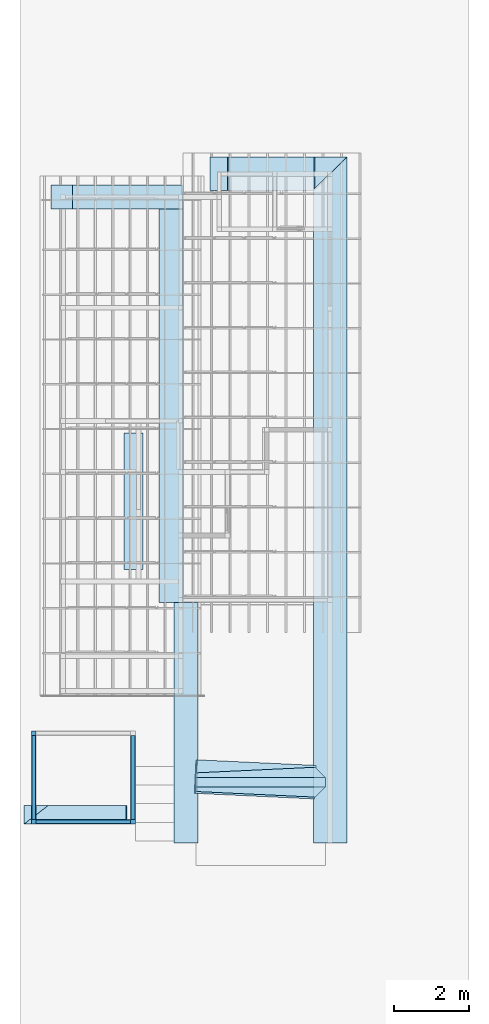
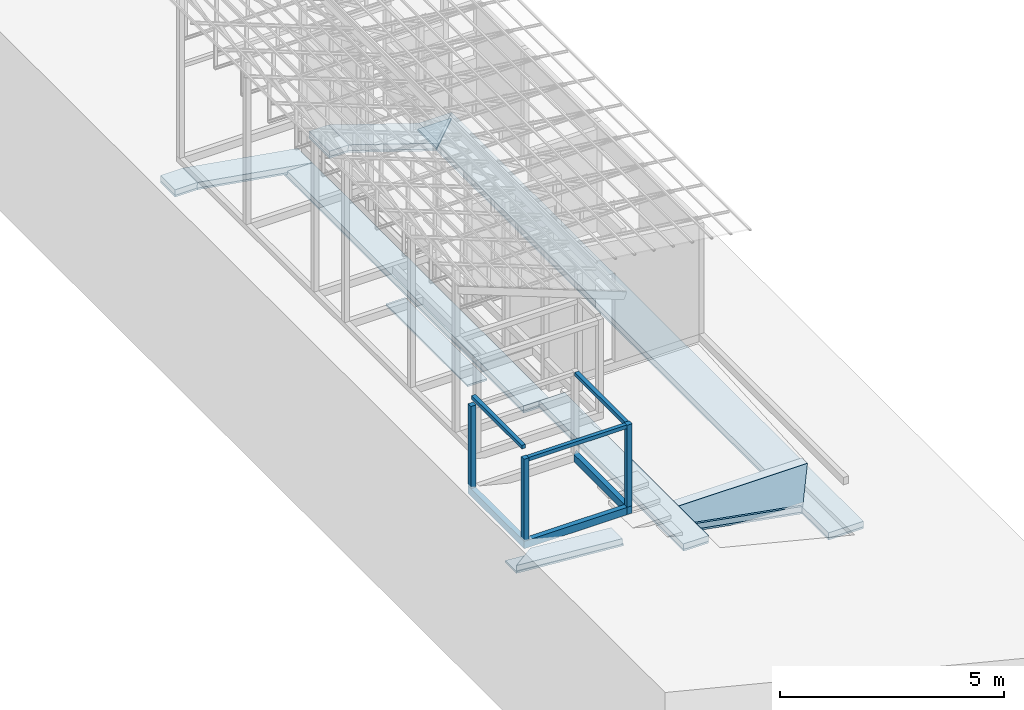
# One storey, part 1 of 22: 22 footings, 9 beams.
"""IFC4 building model written with IfcOpenShell, lengths in millimetres."""

import ifcopenshell
import ifcopenshell.guid

model = None  # the IFC model being written
_history = None  # IfcOwnerHistory: only IFC2X3 demands one
_inside = {}  # id of a spatial element -> (the spatial element, [elements in it])
_under = {}  # id of a project, library or spatial element -> (it, [spatial elements below it])
_declared = {}  # id of a project -> (the project, [libraries it declares])
_typed = {}  # id of a type object -> (the type object, [elements of that type])
_made_of = {}  # id of a material, layer set ... -> (it, [elements and type objects made of it])


def new_model(schema):
    """Start an empty IFC model of exactly this schema.

    Asked for "IFC4X3", IfcOpenShell would pick the latest addendum, in which some entities
    have other attributes; the version numbers below select the first issue.
    IFC2X3 requires an IfcOwnerHistory on every rooted entity: one is made here for all.
    """
    global model, _history
    if schema == "IFC4X3":
        model = ifcopenshell.file(schema_version=(4, 3, 0, 0))
    else:
        model = ifcopenshell.file(schema=schema)
    _inside.clear()
    _under.clear()
    _declared.clear()
    _typed.clear()
    _made_of.clear()
    _history = None
    if model.schema == "IFC2X3":
        org = make("IfcOrganization", Name="unknown")
        user = make(
            "IfcPersonAndOrganization",
            ThePerson=make("IfcPerson", FamilyName="unknown"),
            TheOrganization=org,
        )
        app = make(
            "IfcApplication",
            ApplicationDeveloper=org,
            Version="unknown",
            ApplicationFullName="unknown",
            ApplicationIdentifier="unknown",
        )
        _history = make(
            "IfcOwnerHistory",
            OwningUser=user,
            OwningApplication=app,
            ChangeAction="ADDED",
            CreationDate=0,
        )
    return model


def make(cls, **values):
    """One entity of the class cls with the attributes given. An attribute that is None is left unset."""
    return model.create_entity(
        cls, **{name: value for name, value in values.items() if value is not None}
    )


def entity(cls, *values):
    """Any entity or typed value of the class cls, its attributes in the order of the schema. None: left unset."""
    e = model.create_entity(cls)
    for i, value in enumerate(values):
        if value is not None:
            e[i] = value
    return e


def rooted(cls, **values):
    """An entity with a GlobalId (a new one), such as an element, a storey or a relation."""
    return make(cls, GlobalId=ifcopenshell.guid.new(), OwnerHistory=_history, **values)


def si_unit(unit_type, name, prefix=None):
    """IfcSIUnit, for example si_unit("LENGTHUNIT", "METRE", prefix="MILLI")."""
    return make("IfcSIUnit", UnitType=unit_type, Prefix=prefix, Name=name)


def converted_unit(unit_type, name, factor, base, dimensions=None, offset=None):
    """IfcConversionBasedUnit, such as the inch: factor (a typed value) times the base unit."""
    return make(
        "IfcConversionBasedUnit"
        if offset is None
        else "IfcConversionBasedUnitWithOffset",
        ConversionOffset=offset,
        Dimensions=None
        if dimensions is None
        else entity("IfcDimensionalExponents", *dimensions),
        UnitType=unit_type,
        Name=name,
        ConversionFactor=make(
            "IfcMeasureWithUnit", ValueComponent=factor, UnitComponent=base
        ),
    )


def assignment(units):
    """IfcUnitAssignment: the units of a project."""
    return None if units is None else make("IfcUnitAssignment", Units=units)


def point(xyz):
    """IfcCartesianPoint."""
    return None if xyz is None else make("IfcCartesianPoint", Coordinates=xyz)


def direction(xyz):
    """IfcDirection."""
    return None if xyz is None else make("IfcDirection", DirectionRatios=xyz)


def frame(location, z_axis=None, x_axis=None):
    """IfcAxis2Placement3D, a coordinate frame: its origin and axes. An axis left out is left unset."""
    return make(
        "IfcAxis2Placement3D",
        Location=point(location),
        Axis=direction(z_axis),
        RefDirection=direction(x_axis),
    )


def frame_2d(location, x_axis=None):
    """IfcAxis2Placement2D, a coordinate frame in the plane: its origin and x axis."""
    return make(
        "IfcAxis2Placement2D", Location=point(location), RefDirection=direction(x_axis)
    )


def origin_with_axes():
    """The frame at (0, 0, 0) with the z axis (0, 0, 1) and the x axis (1, 0, 0) written out."""
    return frame((0.0, 0.0, 0.0), z_axis=(0.0, 0.0, 1.0), x_axis=(1.0, 0.0, 0.0))


def origin_2d_with_axis():
    """The frame at (0, 0) in the plane with the x axis (1, 0) written out."""
    return frame_2d((0.0, 0.0), x_axis=(1.0, 0.0))


def place(relative_to, where):
    """IfcLocalPlacement: puts the frame where relative to a parent placement (None: the world)."""
    return make(
        "IfcLocalPlacement", PlacementRelTo=relative_to, RelativePlacement=where
    )


def context(
    kind, dimensions, precision=None, world=None, true_north=None, identifier=None
):
    """IfcGeometricRepresentationContext, for example the 3D "Model" context."""
    return make(
        "IfcGeometricRepresentationContext",
        ContextIdentifier=identifier,
        ContextType=kind,
        CoordinateSpaceDimension=dimensions,
        Precision=precision,
        WorldCoordinateSystem=world,
        TrueNorth=true_north,
    )


def subcontext(parent, identifier, kind, view, scale=None):
    """IfcGeometricRepresentationSubContext, for example "Body" below "Model"."""
    return make(
        "IfcGeometricRepresentationSubContext",
        ContextIdentifier=identifier,
        ContextType=kind,
        ParentContext=parent,
        TargetScale=scale,
        TargetView=view,
    )


def project(units=None, contexts=None):
    """IfcProject with its units and contexts."""
    return rooted(
        "IfcProject",
        Name="project",
        RepresentationContexts=contexts,
        UnitsInContext=assignment(units),
    )


def spatial(cls, under=None, at=None, **own):
    """A site, building, storey or space (cls), placed at a placement, below another one or the project."""
    s = rooted(cls, ObjectPlacement=at, **own)
    if under is not None:
        _under.setdefault(under.id(), (under, []))[1].append(s)
    return s


def point_list(points):
    """IfcCartesianPointList2D or 3D."""
    cls = (
        "IfcCartesianPointList2D" if len(points[0]) == 2 else "IfcCartesianPointList3D"
    )
    return make(cls, CoordList=points)


def indexed_curve(points, segments=None, self_intersect=None):
    """IfcIndexedPolyCurve: lines and arcs through numbered points (the first is 1)."""
    return make(
        "IfcIndexedPolyCurve",
        Points=point_list(points),
        Segments=segments,
        SelfIntersect=self_intersect,
    )


def profile(cls, at=None, kind="AREA", **sizes):
    """A parametric profile (cls). Its sizes go by their IFC names, for example OverallWidth=200.0."""
    return make(cls, ProfileType=kind, Position=at, **sizes)


def rectangle(**sizes):
    """IfcRectangleProfileDef."""
    return profile("IfcRectangleProfileDef", **sizes)


def outline(outer, holes=None, kind="AREA"):
    """IfcArbitraryClosedProfileDef: a profile drawn as a closed curve; with holes, ...WithVoids."""
    if holes is None:
        return make("IfcArbitraryClosedProfileDef", ProfileType=kind, OuterCurve=outer)
    return make(
        "IfcArbitraryProfileDefWithVoids",
        ProfileType=kind,
        OuterCurve=outer,
        InnerCurves=holes,
    )


def extrude(swept, where, along, depth):
    """IfcExtrudedAreaSolid: the profile swept, set in the frame where, extruded along a direction by depth."""
    return make(
        "IfcExtrudedAreaSolid",
        SweptArea=swept,
        Position=where,
        ExtrudedDirection=direction(along),
        Depth=depth,
    )


def clip(a, b, op="DIFFERENCE"):
    """IfcBooleanClippingResult: the solid a cut by the half space b."""
    return make(
        "IfcBooleanClippingResult", Operator=op, FirstOperand=a, SecondOperand=b
    )


def halfspace(plane, agree):
    """IfcHalfSpaceSolid: all space on one side of the plane z = 0 of the frame plane."""
    return make(
        "IfcHalfSpaceSolid",
        BaseSurface=make("IfcPlane", Position=plane),
        AgreementFlag=agree,
    )


def polygons(points, faces, closed=None, point_numbers=None):
    """IfcPolygonalFaceSet: a face is its outer loop, then its inner loops; points numbered from 1."""
    made = []
    for loops in faces:
        if len(loops) == 1:
            made.append(make("IfcIndexedPolygonalFace", CoordIndex=loops[0]))
        else:
            made.append(
                make(
                    "IfcIndexedPolygonalFaceWithVoids",
                    CoordIndex=loops[0],
                    InnerCoordIndices=loops[1:],
                )
            )
    return make(
        "IfcPolygonalFaceSet",
        Coordinates=point_list(points),
        Closed=closed,
        Faces=made,
        PnIndex=point_numbers,
    )


def shape(context_of_items, identifier, shape_type, items):
    """IfcShapeRepresentation: the items that make up one representation, for example the "Body"."""
    return make(
        "IfcShapeRepresentation",
        ContextOfItems=context_of_items,
        RepresentationIdentifier=identifier,
        RepresentationType=shape_type,
        Items=items,
    )


def source(mapping_origin, context_of_items, identifier, shape_type, items):
    """IfcRepresentationMap: a shape defined once, which mapped items show again and again."""
    return make(
        "IfcRepresentationMap",
        MappingOrigin=mapping_origin,
        MappedRepresentation=shape(context_of_items, identifier, shape_type, items),
    )


def transform(
    local_origin,
    x_axis=None,
    y_axis=None,
    z_axis=None,
    scale=None,
    scale2=None,
    scale3=None,
    uniform=True,
):
    """IfcCartesianTransformationOperator3D, or its non-uniform kind. x_axis, y_axis, z_axis: its Axis1, 2, 3."""
    if uniform:
        return make(
            "IfcCartesianTransformationOperator3D",
            Axis1=direction(x_axis),
            Axis2=direction(y_axis),
            LocalOrigin=point(local_origin),
            Scale=scale,
            Axis3=direction(z_axis),
        )
    return make(
        "IfcCartesianTransformationOperator3DnonUniform",
        Axis1=direction(x_axis),
        Axis2=direction(y_axis),
        LocalOrigin=point(local_origin),
        Scale=scale,
        Axis3=direction(z_axis),
        Scale2=scale2,
        Scale3=scale3,
    )


def mapped(mapping_source, mapping_target):
    """IfcMappedItem: shows the shape of a source again, moved by a transform."""
    return make(
        "IfcMappedItem", MappingSource=mapping_source, MappingTarget=mapping_target
    )


def material(Name=None, Category=None):
    """IfcMaterial."""
    return make("IfcMaterial", Name=Name, Category=Category)


def material_profile(
    of_material, cross_section, Name=None, Category=None, Priority=None
):
    """IfcMaterialProfile: a cross section and its material."""
    return make(
        "IfcMaterialProfile",
        Name=Name,
        Material=of_material,
        Profile=cross_section,
        Priority=Priority,
        Category=Category,
    )


def profile_set(profiles, Name=None, composite=None):
    """IfcMaterialProfileSet."""
    return make(
        "IfcMaterialProfileSet",
        Name=Name,
        MaterialProfiles=profiles,
        CompositeProfile=composite,
    )


def profile_usage(for_profile_set, cardinal=None, extent=None):
    """IfcMaterialProfileSetUsage: how a profile set lies along its element."""
    return make(
        "IfcMaterialProfileSetUsage",
        ForProfileSet=for_profile_set,
        CardinalPoint=cardinal,
        ReferenceExtent=extent,
    )


def made_of(thing, what):
    """Note that an element or type object is made of a material, layer set ...; save() writes the relation."""
    if what is not None:
        _made_of.setdefault(what.id(), (what, []))[1].append(thing)
    return thing


def type_object(cls, material=None, **own):
    """A type object (cls), such as IfcWallType, which elements share."""
    return made_of(rooted(cls, **own), material)


def type_shapes(of_type, sources):
    """Give a type object the sources (RepresentationMaps) that its elements show as mapped items."""
    of_type.RepresentationMaps = sources


def element(
    cls,
    number,
    at=None,
    inside=None,
    cuts=None,
    type_object=None,
    material=None,
    context=None,
    identifier="Body",
    shape_type=None,
    held_by="IfcProductDefinitionShape",
    body=None,
    shapes=None,
    **own,
):
    """One element of the class cls, such as IfcWall. Its Tag is "e" and its number.

    at: its placement. inside: the storey or other place that contains it. cuts: it is an
    opening in that element (IfcRelVoidsElement). A single representation is given by context,
    identifier, shape_type and body (its items); several are given by shapes. held_by: the class
    of the entity that holds the representations. save() writes the other relations.
    """
    e = rooted(cls, Tag="e%d" % number, ObjectPlacement=at, **own)
    if body is not None:
        shapes = [shape(context, identifier, shape_type, body)]
    if shapes is not None:
        e.Representation = make(held_by, Representations=shapes)
    if inside is not None:
        _inside.setdefault(inside.id(), (inside, []))[1].append(e)
    if cuts is not None:
        rooted(
            "IfcRelVoidsElement", RelatingBuildingElement=cuts, RelatedOpeningElement=e
        )
    if type_object is not None:
        _typed.setdefault(type_object.id(), (type_object, []))[1].append(e)
    return made_of(e, material)


def aggregate(whole, parts):
    """IfcRelAggregates: a whole, such as a stair, and the parts it consists of."""
    return rooted("IfcRelAggregates", RelatingObject=whole, RelatedObjects=parts)


def save(model, path):
    """Write the relations noted so far, then the file.

    IfcRelAggregates (storeys below a building ...), IfcRelContainedInSpatialStructure (elements
    in a storey), IfcRelDefinesByType, IfcRelAssociatesMaterial and IfcRelDeclares: one each for
    every whole, place, type object, material and project.
    """
    for whole, parts in _under.values():
        aggregate(whole, parts)
    for where, things in _inside.values():
        rooted(
            "IfcRelContainedInSpatialStructure",
            RelatedElements=things,
            RelatingStructure=where,
        )
    for kind, things in _typed.values():
        rooted("IfcRelDefinesByType", RelatedObjects=things, RelatingType=kind)
    for what, things in _made_of.values():
        rooted("IfcRelAssociatesMaterial", RelatedObjects=things, RelatingMaterial=what)
    for by, libraries in _declared.values():
        rooted("IfcRelDeclares", RelatingContext=by, RelatedDefinitions=libraries)
    model.write(path)


model = new_model("IFC4")

# Units and contexts
model_context = context("Model", 3, precision=1e-05, world=origin_with_axes())
plan_context = context("Plan", 2, precision=1e-05, world=origin_2d_with_axis())
body_context = subcontext(model_context, "Body", "Model", "MODEL_VIEW")
ifc_project = project(units=[si_unit("VOLUMEUNIT", "CUBIC_METRE"), si_unit("LENGTHUNIT", "METRE", prefix="MILLI"), si_unit("AREAUNIT", "SQUARE_METRE"), converted_unit("PLANEANGLEUNIT", "degree", entity("IfcReal", 0.0174532925199433), si_unit("PLANEANGLEUNIT", "RADIAN"), dimensions=[0, 0, 0, 0, 0, 0, 0])], contexts=[model_context, plan_context])

# Site, building, storey
site_placement = place(None, origin_with_axes())
site = spatial("IfcSite", under=ifc_project, at=site_placement)
building_placement = place(site_placement, origin_with_axes())
building = spatial("IfcBuilding", under=site, at=building_placement, Name="2")
storey_placement = place(building_placement, frame((0.0, 0.0, 200.000002980232), z_axis=(0.0, 0.0, 1.0), x_axis=(1.0, 0.0, 0.0)))
storey = spatial("IfcBuildingStorey", under=building, at=storey_placement)

# Footings
ifc_material_1 = material()
ifc_material_profile_1 = material_profile(ifc_material_1, rectangle(XDim=900.000061035156, YDim=150.0, kind="CURVE"))
ifc_profile_set_1 = profile_set([ifc_material_profile_1])
ifc_profile_usage_1 = profile_usage(ifc_profile_set_1, cardinal=8)
footing_type_1 = type_object("IfcFootingType", Name="80", PredefinedType="FOOTING_BEAM", material=ifc_profile_set_1)
footing_1_placement = place(storey_placement, frame((8.94069671630859e-05, 8.82570319049591e-05, -1369.00003254414), z_axis=(1.50995802528082e-07, 0.99999999999997, 1.94707183709391e-07), x_axis=(-0.999999999999989, 1.50995802528085e-07, 3.8637609778291e-10)))
element("IfcFooting", 1, at=footing_1_placement, inside=storey, type_object=footing_type_1, material=ifc_profile_usage_1, Name="Footing", context=body_context, shape_type="Clipping", body=[
    clip(extrude(rectangle(XDim=900.000061035156, YDim=150.0, kind="CURVE"), frame((0.0, -75.0, 0.0), z_axis=(0.0, 0.0, 1.0), x_axis=(1.0, 0.0, 0.0)), (0.0, 0.0, 1.0), 18365.0016311497), halfspace(frame((-450.000017881393, 1168.99645328522, 18365.0016784668), z_axis=(0.696755647659302, -1.39665132792288e-07, 0.717308580875397), x_axis=(-2.00450664822711e-07, -0.99999999999998, 0.0)), False)),
])
ifc_profile_usage_2 = profile_usage(ifc_profile_set_1, cardinal=8)
footing_2_placement = place(storey_placement, frame((450.00284910202, 17915.0009155273, -1368.99431049824), z_axis=(-0.999999999986636, 4.37116973722438e-08, -5.16971067547641e-06), x_axis=(-4.37113882867378e-08, -0.999999999999997, -5.96044884559886e-08)))
element("IfcFooting", 2, at=footing_2_placement, inside=storey, type_object=footing_type_1, material=ifc_profile_usage_2, Name="Footing", context=body_context, shape_type="Clipping", body=[
    clip(clip(extrude(rectangle(XDim=900.000061035156, YDim=150.0, kind="CURVE"), frame((0.0, -75.0, 0.0), z_axis=(0.0, 0.0, 1.0), x_axis=(1.0, 0.0, 0.0)), (0.0, 0.0, 1.0), 2200.9535023958), halfspace(frame((-450.000792741776, 1168.99430751801, -0.00608157097303774), z_axis=(0.717308640480042, -3.55953898178996e-06, -0.696755588054657), x_axis=(-4.96235341507108e-06, -0.999999999987688, 0.0)), False)), halfspace(frame((17915.0009155273, -149.998858571053, 874.211609363556), z_axis=(3.36546861490206e-08, 0.15935792028904, 0.987220823764801), x_axis=(0.999999999999978, -2.11189290673333e-07, 0.0)), False)),
])
ifc_profile_usage_3 = profile_usage(ifc_profile_set_1, cardinal=8)
footing_3_placement = place(storey_placement, frame((906.826019287109, 17915.0009155273, -1802.16391384602), z_axis=(-0.949214158464381, 1.49872287242176e-07, 0.314630706337977), x_axis=(-1.62920684942944e-07, -0.999999999999987, -1.51743648757472e-08)))
element("IfcFooting", 3, at=footing_3_placement, inside=storey, type_object=footing_type_1, material=ifc_profile_usage_3, Name="Footing", context=body_context, shape_type="Clipping", body=[
    clip(clip(extrude(rectangle(XDim=900.000061035156, YDim=150.0, kind="CURVE"), frame((0.0, -75.0, 0.0), z_axis=(0.0, 0.0, 1.0), x_axis=(1.0, 0.0, 0.0)), (0.0, 0.0, 1.0), 4720.87314664119), halfspace(frame((17915.0009155273, 0.0012516975402832, 3820.87016105652), z_axis=(1.58420789375668e-07, -0.159351527690887, 0.987221896648407), x_axis=(-0.999999999999506, -9.94159213100844e-07, 0.0)), False)), halfspace(frame((17915.0009155273, -149.999037384987, 1352.52726078033), z_axis=(-1.58420746743104e-07, 0.159350320696831, -0.987222075462341), x_axis=(0.999999999999506, 9.94166475789068e-07, 0.0)), False)),
])
ifc_profile_usage_4 = profile_usage(ifc_profile_set_1, cardinal=8)
footing_4_placement = place(storey_placement, frame((-1820.00160217285, 17915.0009155273, -599.999889731407), z_axis=(-0.999999999999998, 4.37113873394259e-08, -4.37113873394259e-08), x_axis=(-4.37113873394259e-08, -0.999999999999999, 0.0)))
element("IfcFooting", 4, at=footing_4_placement, inside=storey, type_object=footing_type_1, material=ifc_profile_usage_4, Name="Footing", context=body_context, shape_type="Clipping", body=[
    clip(extrude(rectangle(XDim=900.000061035156, YDim=150.0, kind="CURVE"), frame((0.0, -75.0, 0.0), z_axis=(0.0, 0.0, 1.0), x_axis=(1.0, 0.0, 0.0)), (0.0, 0.0, 1.0), 1400.00035422184), halfspace(frame((17915.0009155273, -3.14301473736123e-07, 899.999618530273), z_axis=(-4.3152841300298e-08, -0.159351646900177, -0.987222075462341), x_axis=(-0.999999999999963, 2.70802606309608e-07, 0.0)), False)),
])
ifc_profile_usage_5 = profile_usage(ifc_profile_set_1, cardinal=8)
footing_5_placement = place(storey_placement, frame((-399.999558925629, 1625.00011920929, -1368.99991333485), z_axis=(-0.988259350660575, 0.0465428482409231, 0.145523946859482), x_axis=(-0.0470436397590824, -0.99889283507202, 8.11148474691124e-09)))
element("IfcFooting", 5, at=footing_5_placement, inside=storey, type_object=footing_type_1, material=ifc_profile_usage_5, Name="Footing", context=body_context, shape_type="SweptSolid", body=[
    extrude(rectangle(XDim=900.000061035156, YDim=150.0, kind="CURVE"), frame((0.0, -75.0, 0.0), z_axis=(0.0, 0.0, 1.0), x_axis=(1.0, 0.0, 0.0)), (0.0, 0.0, 1.0), 3222.83868995742),
])
ifc_material_profile_2 = material_profile(ifc_material_1, rectangle(XDim=650.000061035156, YDim=150.0, kind="CURVE"))
ifc_profile_set_2 = profile_set([ifc_material_profile_2])
ifc_profile_usage_6 = profile_usage(ifc_profile_set_2, cardinal=9)
footing_type_2 = type_object("IfcFootingType", Name="60", PredefinedType="FOOTING_BEAM", material=ifc_profile_set_2)
footing_6_placement = place(storey_placement, frame((-3535.00056266785, 0.00149925722325861, -364.99947309494), z_axis=(6.27832946520202e-07, 0.999999999999754, 3.13916473260101e-07), x_axis=(-0.999999999999797, 6.2783294652023e-07, -1.09128812653103e-07)))
element("IfcFooting", 6, at=footing_6_placement, inside=storey, type_object=footing_type_2, material=ifc_profile_usage_6, Name="Footing", context=body_context, shape_type="SweptSolid", body=[
    extrude(rectangle(XDim=650.000061035156, YDim=150.0, kind="CURVE"), frame((325.000030517578, -75.0, 0.0), z_axis=(0.0, 0.0, 1.0), x_axis=(1.0, 0.0, 0.0)), (0.0, 0.0, 1.0), 6434.99885043491),
])
ifc_profile_usage_7 = profile_usage(ifc_profile_set_2, cardinal=9)
footing_7_placement = place(storey_placement, frame((-3934.99493598938, 6435.00089645386, -364.996150135994), z_axis=(1.50995816738937e-07, 0.99999999999997, 1.94707183709391e-07), x_axis=(-0.999999999999986, 1.50995802528085e-07, 7.09954122157787e-08)))
element("IfcFooting", 7, at=footing_7_placement, inside=storey, type_object=footing_type_2, material=ifc_profile_usage_7, Name="Footing", context=body_context, shape_type="SweptSolid", body=[
    extrude(rectangle(XDim=650.000061035156, YDim=150.0, kind="CURVE"), frame((325.000030517578, -75.0, 0.0), z_axis=(0.0, 0.0, 1.0), x_axis=(1.0, 0.0, 0.0)), (0.0, 0.0, 1.0), 10739.9997772278),
])
ifc_profile_usage_8 = profile_usage(ifc_profile_set_2, cardinal=8)
footing_8_placement = place(storey_placement, frame((-3934.99302864075, 17300.0011444092, -364.994779229164), z_axis=(-0.986077590498589, 3.40529163719693e-08, 0.166285854829856), x_axis=(-4.37113882867378e-08, -0.999999999999998, -5.44237792610146e-08)))
element("IfcFooting", 8, at=footing_8_placement, inside=storey, type_object=footing_type_2, material=ifc_profile_usage_8, Name="Footing", context=body_context, shape_type="Clipping", body=[
    clip(extrude(rectangle(XDim=650.000061035156, YDim=150.0, kind="CURVE"), frame((0.0, -75.0, 0.0), z_axis=(0.0, 0.0, 1.0), x_axis=(1.0, 0.0, 0.0)), (0.0, 0.0, 1.0), 3656.86580574654), halfspace(frame((17299.9954223633, -2.9802624368358e-05, 3006.8781375885), z_axis=(-6.75377066272631e-07, -0.083430215716362, 0.996513605117798), x_axis=(-0.999999999967235, 8.0951135083551e-06, 0.0)), False)),
])
ifc_profile_usage_9 = profile_usage(ifc_profile_set_2, cardinal=8)
footing_9_placement = place(storey_placement, frame((-6249.99618530273, 17300.0011444092, 135.004326701164), z_axis=(-0.999999999999962, -1.94707164287728e-07, 1.94707178498585e-07), x_axis=(1.94707178498587e-07, -0.999999999999974, 1.19209289550778e-07)))
element("IfcFooting", 9, at=footing_9_placement, inside=storey, type_object=footing_type_2, material=ifc_profile_usage_9, Name="Footing", context=body_context, shape_type="Clipping", body=[
    clip(extrude(rectangle(XDim=650.000061035156, YDim=150.0, kind="CURVE"), frame((0.0, -75.0, 0.0), z_axis=(0.0, 0.0, 1.0), x_axis=(1.0, 0.0, 0.0)), (0.0, 0.0, 1.0), 1224.99893538763), halfspace(frame((17299.9973297119, -0.00101565490240318, 650.015890598297), z_axis=(8.98476798738557e-07, -0.0834372565150261, -0.99651300907135), x_axis=(-0.999999999942022, -1.07682926813954e-05, 0.0)), False)),
])
ifc_material_2 = material()
footing_type_3 = type_object("IfcFootingType", Name="Type 6", PredefinedType="STRIP_FOOTING")
shared_shape = source(origin_with_axes(), body_context, "Body", "Tessellation", [
    polygons([(-3459.99975585938, -249.999969482422, -399.999816894531), (-3459.99975585938, 249.999984741211, -399.999816894531), (-3459.99975585938, 124.999992370605, 0.0), (-3459.99975585938, -124.999977111816, 0.0), (-5.46392266187468e-06, 124.999984741211, 0.0), (5.46392266187468e-06, -124.999984741211, 0.0), (-274.999572753906, 399.999938964844, -868.999755859375), (-274.999542236328, -399.999938964844, -868.999755859375)], [[[3, 1, 2]], [[3, 4, 1]], [[4, 5, 6]], [[3, 5, 4]], [[8, 7, 1]], [[7, 3, 2]], [[6, 1, 4]], [[1, 7, 2]], [[3, 7, 5]], [[6, 8, 1]], [[8, 6, 5]], [[8, 5, 7]]]),
])
type_shapes(footing_type_3, [shared_shape])
footing_10_placement = place(storey_placement, frame((-124.999761581421, 1625.00035762787, -500.00025331974), z_axis=(0.0, 0.0, 1.0), x_axis=(1.0, 0.0, 0.0)))
element("IfcFooting", 10, at=footing_10_placement, inside=storey, type_object=footing_type_3, material=ifc_material_2, Name="Footing", context=body_context, shape_type="MappedRepresentation", body=[
    mapped(shared_shape, transform((0.0, 0.0, 0.0), x_axis=(1.0, 0.0, 0.0), y_axis=(0.0, 1.0, 0.0), z_axis=(0.0, 0.0, 1.0), scale=1.0)),
])
ifc_material_profile_3 = material_profile(ifc_material_1, rectangle(XDim=500.0, YDim=150.0, kind="CURVE"))
ifc_profile_set_3 = profile_set([ifc_material_profile_3])
ifc_profile_usage_10 = profile_usage(ifc_profile_set_3)
footing_type_4 = type_object("IfcFootingType", Name="50", PredefinedType="FOOTING_BEAM", material=ifc_profile_set_3)
footing_11_placement = place(storey_placement, frame((-8698.29750061035, 750.003755092621, 117.41553246975), z_axis=(0.996607147811859, 2.88828267531261e-07, -0.0823054854200311), x_axis=(-2.82129974493715e-07, 0.999999999999956, 9.30135541921077e-08)))
element("IfcFooting", 11, at=footing_11_placement, inside=storey, type_object=footing_type_4, material=ifc_profile_usage_10, Name="Footing", context=body_context, shape_type="Clipping", body=[
    clip(extrude(rectangle(XDim=500.0, YDim=150.0, kind="CURVE"), origin_with_axes(), (0.0, 0.0, 1.0), 3239.81487830733), halfspace(frame((-249.999985098839, -275.324583053589, 522.738575935364), z_axis=(0.792623698711395, -0.0501824878156185, -0.607642531394958), x_axis=(-0.0631853598244384, -0.998001808767828, 0.0)), False)),
])
ifc_material_3 = material()
ifc_material_profile_4 = material_profile(ifc_material_3, rectangle(XDim=500.0, YDim=50.0, kind="CURVE"))
ifc_profile_set_4 = profile_set([ifc_material_profile_4])
ifc_profile_usage_11 = profile_usage(ifc_profile_set_4)
footing_type_5 = type_object("IfcFootingType", Name="50", PredefinedType="FOOTING_BEAM", material=ifc_profile_set_4)
footing_12_placement = place(storey_placement, frame((-8698.52924346924, 750.003576278687, -2.01705098152138), z_axis=(0.997069925724305, 4.07608313842891e-07, -0.076495511083739), x_axis=(-4.01339264044475e-07, 0.999999999999915, 9.73263780679107e-08)))
element("IfcFooting", 12, at=footing_12_placement, inside=storey, type_object=footing_type_5, material=ifc_profile_usage_11, Name="Footing", context=body_context, shape_type="Clipping", body=[
    clip(extrude(rectangle(XDim=500.0, YDim=50.0, kind="CURVE"), origin_with_axes(), (0.0, 0.0, 1.0), 3267.87439703044), halfspace(frame((2475.00252723694, 25.1914653927088, 498.068064451218), z_axis=(4.013392356228e-07, -0.0764954164624214, -0.997069895267487), x_axis=(-0.999999999986237, -5.24657886939455e-06, 0.0)), False)),
])
ifc_profile_usage_12 = profile_usage(ifc_profile_set_4, cardinal=9)
footing_13_placement = place(storey_placement, frame((-5514.99557495117, 10975.004196167, -14.9987637996671), z_axis=(-1.30640139388225e-07, -0.999999999999989, 7.54978986586405e-08), x_axis=(0.999999999999992, -1.30640145812321e-07, 5.02429578180088e-15)))
element("IfcFooting", 13, at=footing_13_placement, inside=storey, type_object=footing_type_5, material=ifc_profile_usage_12, Name="Footing", context=body_context, shape_type="SweptSolid", body=[
    extrude(rectangle(XDim=500.0, YDim=50.0, kind="CURVE"), frame((250.0, -25.0, 0.0), z_axis=(0.0, 0.0, 1.0), x_axis=(1.0, 0.0, 0.0)), (0.0, 0.0, 1.0), 3650.00434248161),
])
ifc_material_profile_5 = material_profile(ifc_material_3, rectangle(XDim=650.000061035156, YDim=50.0, kind="CURVE"))
ifc_profile_set_5 = profile_set([ifc_material_profile_5])
ifc_profile_usage_13 = profile_usage(ifc_profile_set_5, cardinal=8)
footing_type_6 = type_object("IfcFootingType", Name="60", PredefinedType="FOOTING_BEAM", material=ifc_profile_set_5)
footing_14_placement = place(storey_placement, frame((-4259.9949836731, 6435.00089645386, -514.996156096458), z_axis=(1.50995816738937e-07, 0.99999999999997, 1.94707183709391e-07), x_axis=(-0.999999999999986, 1.50995802528085e-07, 7.09954122157787e-08)))
element("IfcFooting", 14, at=footing_14_placement, inside=storey, type_object=footing_type_6, material=ifc_profile_usage_13, Name="Footing", context=body_context, shape_type="SweptSolid", body=[
    extrude(rectangle(XDim=650.000061035156, YDim=50.0, kind="CURVE"), frame((0.0, -25.0, 0.0), z_axis=(0.0, 0.0, 1.0), x_axis=(1.0, 0.0, 0.0)), (0.0, 0.0, 1.0), 10739.9997772277),
])
ifc_profile_usage_14 = profile_usage(ifc_profile_set_5, cardinal=8)
footing_15_placement = place(storey_placement, frame((-3934.99302864075, 17300.0011444092, -514.99505341053), z_axis=(-0.986077590498589, 3.40529163719693e-08, 0.166285854829856), x_axis=(-4.37113882867378e-08, -0.999999999999998, -5.44237792610146e-08)))
element("IfcFooting", 15, at=footing_15_placement, inside=storey, type_object=footing_type_6, material=ifc_profile_usage_14, Name="Footing", context=body_context, shape_type="Clipping", body=[
    clip(extrude(rectangle(XDim=650.000061035156, YDim=50.0, kind="CURVE"), frame((0.0, -25.0, 0.0), z_axis=(0.0, 0.0, 1.0), x_axis=(1.0, 0.0, 0.0)), (0.0, 0.0, 1.0), 3606.86762940376), halfspace(frame((17299.9954223633, -1.49014613981535e-05, 3006.88004493713), z_axis=(-6.75377236802888e-07, -0.0834270492196083, 0.996513903141022), x_axis=(-0.999999999967232, 8.09542280469413e-06, 0.0)), False)),
])
ifc_profile_usage_15 = profile_usage(ifc_profile_set_5, cardinal=8)
footing_16_placement = place(storey_placement, frame((-6299.99780654907, 17300.0011444092, -14.9956792593), z_axis=(-0.999999999999962, -1.94707169498535e-07, 1.9470718370939e-07), x_axis=(1.94707183709392e-07, -0.999999999999974, 1.19209289550778e-07)))
element("IfcFooting", 16, at=footing_16_placement, inside=storey, type_object=footing_type_6, material=ifc_profile_usage_15, Name="Footing", context=body_context, shape_type="Clipping", body=[
    clip(extrude(rectangle(XDim=650.000061035156, YDim=50.0, kind="CURVE"), frame((0.0, -25.0, 0.0), z_axis=(0.0, 0.0, 1.0), x_axis=(1.0, 0.0, 0.0)), (0.0, 0.0, 1.0), 1174.9973155052), halfspace(frame((17299.9973297119, -0.00106035884073208, 600.016176700592), z_axis=(8.98477708233258e-07, -0.0834309831261635, -0.996513605117798), x_axis=(-0.999999999942013, -1.07691132780072e-05, 0.0)), False)),
])
ifc_profile_usage_16 = profile_usage(ifc_profile_set_5, cardinal=8)
footing_17_placement = place(storey_placement, frame((-3860.00037193298, 0.00175039042460412, -514.999523758888), z_axis=(6.27832946520202e-07, 0.999999999999754, 3.13916473260101e-07), x_axis=(-0.999999999999797, 6.2783294652023e-07, -1.09128812653103e-07)))
element("IfcFooting", 17, at=footing_17_placement, inside=storey, type_object=footing_type_6, material=ifc_profile_usage_16, Name="Footing", context=body_context, shape_type="SweptSolid", body=[
    extrude(rectangle(XDim=650.000061035156, YDim=50.0, kind="CURVE"), frame((0.0, -25.0, 0.0), z_axis=(0.0, 0.0, 1.0), x_axis=(1.0, 0.0, 0.0)), (0.0, 0.0, 1.0), 6434.99885043491),
])
ifc_material_profile_6 = material_profile(ifc_material_3, rectangle(XDim=900.000061035156, YDim=50.0, kind="CURVE"))
ifc_profile_set_6 = profile_set([ifc_material_profile_6])
ifc_profile_usage_17 = profile_usage(ifc_profile_set_6, cardinal=9)
footing_type_7 = type_object("IfcFootingType", Name="80", PredefinedType="FOOTING_BEAM", material=ifc_profile_set_6)
footing_18_placement = place(storey_placement, frame((450.000107288361, 4.95149947710161e-05, -1519.00000870228), z_axis=(1.50995797317274e-07, 0.999999999999939, 3.13916463549329e-07), x_axis=(-0.999999999999989, 1.50995797317281e-07, -7.74240787112221e-11)))
element("IfcFooting", 18, at=footing_18_placement, inside=storey, type_object=footing_type_7, material=ifc_profile_usage_17, Name="Footing", context=body_context, shape_type="Clipping", body=[
    clip(extrude(rectangle(XDim=900.000061035156, YDim=50.0, kind="CURVE"), frame((450.000030517578, -25.0, 0.0), z_axis=(0.0, 0.0, 1.0), x_axis=(1.0, 0.0, 0.0)), (0.0, 0.0, 1.0), 18365.0016311502), halfspace(frame((-2.83801000477979e-05, 1318.99309158325, 18365.0035858154), z_axis=(0.70710676908493, -2.64119336179647e-07, 0.70710688829422), x_axis=(-3.73521153702752e-07, -0.99999999999993, 0.0)), False)),
])
ifc_profile_usage_18 = profile_usage(ifc_profile_set_6, cardinal=9)
footing_19_placement = place(storey_placement, frame((450.002878904343, 18365.0016784668, -1518.99643242359), z_axis=(-0.999999999996444, 4.37112336252521e-08, -2.66631591281924e-06), x_axis=(-4.37113873394258e-08, -0.999999999999997, 5.96047122769544e-08)))
element("IfcFooting", 19, at=footing_19_placement, inside=storey, type_object=footing_type_7, material=ifc_profile_usage_18, Name="Footing", context=body_context, shape_type="Clipping", body=[
    clip(clip(extrude(rectangle(XDim=900.000061035156, YDim=50.0, kind="CURVE"), frame((450.000030517578, -25.0, 0.0), z_axis=(0.0, 0.0, 1.0), x_axis=(1.0, 0.0, 0.0)), (0.0, 0.0, 1.0), 1907.33769138144), halfspace(frame((18365.0035858154, -49.9998740851879, 882.283449172974), z_axis=(-4.08596747547563e-08, 0.159346356987953, 0.987222850322723), x_axis=(0.999999999999967, 2.5642051394902e-07, 0.0)), False)), halfspace(frame((-1.96703169308421e-05, 1318.99547576904, -0.00354837925442553), z_axis=(0.717309474945068, -1.85771466476581e-06, -0.69675487279892), x_axis=(-2.58983706426273e-06, -0.999999999996646, 0.0)), False)),
])
ifc_profile_usage_19 = profile_usage(ifc_profile_set_6, cardinal=9)
footing_20_placement = place(storey_placement, frame((580.928444862366, 18365.0016784668, -1852.16589272022), z_axis=(-0.949214158464381, 1.49872287242176e-07, 0.314630706337977), x_axis=(-1.62920684942944e-07, -0.999999999999987, -1.51743648757472e-08)))
element("IfcFooting", 20, at=footing_20_placement, inside=storey, type_object=footing_type_7, material=ifc_profile_usage_19, Name="Footing", context=body_context, shape_type="Clipping", body=[
    clip(clip(extrude(rectangle(XDim=900.000061035156, YDim=50.0, kind="CURVE"), frame((450.000030517578, -25.0, 0.0), z_axis=(0.0, 0.0, 1.0), x_axis=(1.0, 0.0, 0.0)), (0.0, 0.0, 1.0), 4403.04665424721), halfspace(frame((18364.9997711182, 0.00160932540893555, 3503.04293632507), z_axis=(2.51932760875206e-07, -0.159365549683571, 0.98721969127655), x_axis=(-0.99999999999875, -1.58084831618325e-06, 0.0)), False)), halfspace(frame((18364.9997711182, -49.9983578920364, 1050.84371566772), z_axis=(-6.49109068717735e-08, 0.15935942530632, -0.987220644950867), x_axis=(0.999999999999917, 4.07323926695874e-07, 0.0)), False)),
])
ifc_profile_usage_20 = profile_usage(ifc_profile_set_6, cardinal=9)
footing_21_placement = place(storey_placement, frame((-1844.21300888062, 18365.0016784668, -749.999836087227), z_axis=(-0.999999999999986, 4.37114006029697e-08, -1.62920690153749e-07), x_axis=(-4.37113899448279e-08, -0.999999999999997, -5.96046376699623e-08)))
element("IfcFooting", 21, at=footing_21_placement, inside=storey, type_object=footing_type_7, material=ifc_profile_usage_20, Name="Footing", context=body_context, shape_type="Clipping", body=[
    clip(extrude(rectangle(XDim=900.000061035156, YDim=50.0, kind="CURVE"), frame((450.000030517578, -25.0, 0.0), z_axis=(0.0, 0.0, 1.0), x_axis=(1.0, 0.0, 0.0)), (0.0, 0.0, 1.0), 1375.78724952444), halfspace(frame((18365.0035858154, 0.00116234468805487, 899.997591972351), z_axis=(-1.27166728702832e-07, -0.159342527389526, -0.987223446369171), x_axis=(-0.999999999999682, 7.98071492815737e-07, 0.0)), False)),
])
ifc_profile_usage_21 = profile_usage(ifc_profile_set_6, cardinal=9)
footing_22_placement = place(storey_placement, frame((-400.634348392487, 2075.52886009216, -1517.40308105946), z_axis=(-0.988259361636092, 0.0465429828682726, 0.145523829266369), x_axis=(-0.0470437587045471, -0.998892829470178, 1.03026023574458e-07)))
element("IfcFooting", 22, at=footing_22_placement, inside=storey, type_object=footing_type_7, material=ifc_profile_usage_21, Name="Footing", context=body_context, shape_type="SweptSolid", body=[
    extrude(rectangle(XDim=900.000061035156, YDim=50.0, kind="CURVE"), frame((450.000030517578, -25.0, 0.0), z_axis=(0.0, 0.0, 1.0), x_axis=(1.0, 0.0, 0.0)), (0.0, 0.0, 1.0), 3222.83868071019),
])

# Beams
ifc_material_4 = material(Name="Concrete")
ifc_material_profile_7 = material_profile(ifc_material_4, outline(indexed_curve([(-65.0, 99.9999923706055), (65.0, 99.9999923706055), (65.0, -99.9999923706055), (-65.0, -99.9999923706055), (-65.0, 99.9999923706055)])))
ifc_profile_set_7 = profile_set([ifc_material_profile_7])
ifc_profile_usage_22 = profile_usage(ifc_profile_set_7, cardinal=5)
beam_type_1 = type_object("IfcBeamType", PredefinedType="BEAM", material=ifc_profile_set_7)
beam_1_placement = place(storey_placement, frame((-5279.99591827393, 500.004768371582, 635.000213980675), z_axis=(6.27832946520202e-07, 0.999999999999754, 3.13916473260101e-07), x_axis=(-0.999999999999803, 6.27832946520233e-07, -2.42417659279633e-08)))
element("IfcBeam", 23, at=beam_1_placement, inside=storey, type_object=beam_type_1, material=ifc_profile_usage_22, Name="Beam", PredefinedType="BEAM", context=body_context, shape_type="Clipping", body=[
    clip(extrude(outline(indexed_curve([(-65.0, 99.9999923706055), (65.0, 99.9999923706055), (65.0, -99.9999923706055), (-65.0, -99.9999923706055), (-65.0, 99.9999923706055)])), origin_with_axes(), (0.0, 0.0, 1.0), 2499.99980926566), halfspace(frame((-65.0000795722008, -835.001826286316, 2499.99928474426), z_axis=(0.707107186317444, -3.90559591778583e-07, 0.707106351852417), x_axis=(-5.52334355152754e-07, -0.999999999999847, 0.0)), False)),
])
ifc_profile_usage_23 = profile_usage(ifc_profile_set_7, cardinal=1)
beam_2_placement = place(storey_placement, frame((-5220.00026702881, 500.004768371582, 535.000130534172), z_axis=(-0.999999999999978, -7.5497908369469e-08, 1.94707183709393e-07), x_axis=(7.5497901264043e-08, -0.999999999999995, -5.96046660916724e-08)))
element("IfcBeam", 24, at=beam_2_placement, inside=storey, type_object=beam_type_1, material=ifc_profile_usage_23, Name="Beam", PredefinedType="BEAM", context=body_context, shape_type="Clipping", body=[
    clip(extrude(outline(indexed_curve([(-65.0, 99.9999923706055), (65.0, 99.9999923706055), (65.0, -99.9999923706055), (-65.0, -99.9999923706055), (-65.0, 99.9999923706055)])), frame((-65.0000076293945, 100.0, 0.0), z_axis=(0.0, 0.0, 1.0), x_axis=(1.0, 0.0, 0.0)), (0.0, 0.0, 1.0), 2779.99446689967), halfspace(frame((5.16682625573139e-05, -734.999418258667, 2779.99448776245), z_axis=(-0.707107126712799, -9.83517978170312e-09, 0.707106351852417), x_axis=(-1.39090378390399e-08, 1.0, 0.0)), False)),
])
ifc_profile_usage_24 = profile_usage(ifc_profile_set_7, cardinal=1)
beam_3_placement = place(storey_placement, frame((-7999.99475479126, 500.004529953003, 535.000905394554), z_axis=(-1.8171121684704e-14, 0.999999999999906, -4.33125762810919e-07), x_axis=(-0.999999999999989, 4.72290494202531e-14, 1.50995802528085e-07)))
element("IfcBeam", 25, at=beam_3_placement, inside=storey, type_object=beam_type_1, material=ifc_profile_usage_24, Name="Beam", PredefinedType="BEAM", context=body_context, shape_type="Clipping", body=[
    clip(clip(extrude(outline(indexed_curve([(-65.0, 99.9999923706055), (65.0, 99.9999923706055), (65.0, -99.9999923706055), (-65.0, -99.9999923706055), (-65.0, 99.9999923706055)])), frame((-65.0000076293945, 100.0, 0.0), z_axis=(0.0, 0.0, 1.0), x_axis=(1.0, 0.0, 0.0)), (0.0, 0.0, 1.0), 2500.00171661344), halfspace(frame((2.16715534406831e-10, -734.999358654022, 2500.00166893005), z_axis=(-0.70710676908493, 1.37678824785326e-07, 0.70710676908493), x_axis=(1.94707264595266e-07, 0.999999999999981, 0.0)), False)), halfspace(frame((2.1316282072803e-10, -734.999716281891, 0.000357627470748412), z_axis=(-0.707106411457062, -3.69486571116795e-07, -0.707107067108154), x_axis=(-5.22533193208334e-07, 0.999999999999864, 0.0)), False)),
])
ifc_material_profile_8 = material_profile(ifc_material_4, rectangle(XDim=130.000015258789, YDim=130.000015258789, kind="CURVE"))
ifc_profile_set_8 = profile_set([ifc_material_profile_8])
ifc_profile_usage_25 = profile_usage(ifc_profile_set_8, cardinal=5)
beam_type_2 = type_object("IfcBeamType", PredefinedType="BEAM", material=ifc_profile_set_8)
beam_4_placement = place(storey_placement, frame((-5279.99591827393, 565.004646778107, 735.000178217888), z_axis=(0.0, 0.0, 1.0), x_axis=(1.0, 0.0, 0.0)))
element("IfcBeam", 26, at=beam_4_placement, inside=storey, type_object=beam_type_2, material=ifc_profile_usage_25, Name="Column", PredefinedType="BEAM", context=body_context, shape_type="SweptSolid", body=[
    extrude(rectangle(XDim=130.000015258789, YDim=130.000015258789, kind="CURVE"), origin_with_axes(), (0.0, 0.0, 1.0), 2235.00105616739),
])
ifc_profile_usage_26 = profile_usage(ifc_profile_set_8, cardinal=5)
beam_5_placement = place(storey_placement, frame((-7934.99422073364, 565.004467964172, 735.000655055046), z_axis=(0.0, 0.0, 1.0), x_axis=(1.0, 0.0, 0.0)))
element("IfcBeam", 27, at=beam_5_placement, inside=storey, type_object=beam_type_2, material=ifc_profile_usage_26, Name="Column", PredefinedType="BEAM", context=body_context, shape_type="SweptSolid", body=[
    extrude(rectangle(XDim=130.000015258789, YDim=130.000015258789, kind="CURVE"), origin_with_axes(), (0.0, 0.0, 1.0), 2235.00062946763),
])
ifc_profile_usage_27 = profile_usage(ifc_profile_set_8, cardinal=5)
beam_6_placement = place(storey_placement, frame((-7934.99517440796, 2935.00590324402, 734.999820590019), z_axis=(0.0, 0.0, 1.0), x_axis=(1.0, 0.0, 0.0)))
element("IfcBeam", 28, at=beam_6_placement, inside=storey, type_object=beam_type_2, material=ifc_profile_usage_27, Name="Column", PredefinedType="BEAM", context=body_context, shape_type="SweptSolid", body=[
    extrude(rectangle(XDim=130.000015258789, YDim=130.000015258789, kind="CURVE"), origin_with_axes(), (0.0, 0.0, 1.0), 2235.00158954197),
])
ifc_material_profile_9 = material_profile(ifc_material_4, rectangle(XDim=100.0, YDim=100.0))
ifc_profile_set_9 = profile_set([ifc_material_profile_9])
ifc_profile_usage_28 = profile_usage(ifc_profile_set_9, cardinal=2)
beam_type_3 = type_object("IfcBeamType", PredefinedType="BEAM", material=ifc_profile_set_9)
beam_7_placement = place(storey_placement, frame((-5344.99597549438, 565.004467964172, 2870.00136077404), z_axis=(-0.999999999999978, -7.5497908369469e-08, 1.94707183709393e-07), x_axis=(7.5497901264043e-08, -0.999999999999995, -5.96046660916724e-08)))
element("IfcBeam", 29, at=beam_7_placement, inside=storey, type_object=beam_type_3, material=ifc_profile_usage_28, Name="Beam", PredefinedType="BEAM", context=body_context, shape_type="SweptSolid", body=[
    extrude(rectangle(XDim=100.0, YDim=100.0), frame((0.0, 50.0, 0.0), z_axis=(0.0, 0.0, 1.0), x_axis=(1.0, 0.0, 0.0)), (0.0, 0.0, 1.0), 2524.99823239714),
])
ifc_profile_usage_29 = profile_usage(ifc_profile_set_9, cardinal=2)
beam_8_placement = place(storey_placement, frame((-7934.99422073364, 630.004286766052, 3165.00096023083), z_axis=(-1.8171121684704e-14, 0.999999999999906, -4.33125762810919e-07), x_axis=(-0.999999999999989, 4.72290494202531e-14, 1.50995802528085e-07)))
element("IfcBeam", 30, at=beam_8_placement, inside=storey, type_object=beam_type_3, material=ifc_profile_usage_29, Name="Beam", PredefinedType="BEAM", context=body_context, shape_type="SweptSolid", body=[
    extrude(rectangle(XDim=100.0, YDim=100.0), frame((0.0, 50.0, 0.0), z_axis=(0.0, 0.0, 1.0), x_axis=(1.0, 0.0, 0.0)), (0.0, 0.0, 1.0), 2240.00171627272),
])
ifc_profile_usage_30 = profile_usage(ifc_profile_set_9, cardinal=2)
beam_9_placement = place(storey_placement, frame((-5279.99591827393, 630.004823207855, 2870.00136077404), z_axis=(6.27832946520202e-07, 0.999999999999754, 3.13916473260101e-07), x_axis=(-0.999999999999803, 6.27832946520233e-07, -2.42417659279633e-08)))
element("IfcBeam", 31, at=beam_9_placement, inside=storey, type_object=beam_type_3, material=ifc_profile_usage_30, Name="Beam", PredefinedType="BEAM", context=body_context, shape_type="SweptSolid", body=[
    extrude(rectangle(XDim=100.0, YDim=100.0), frame((0.0, 50.0, 0.0), z_axis=(0.0, 0.0, 1.0), x_axis=(1.0, 0.0, 0.0)), (0.0, 0.0, 1.0), 2239.9994810995),
])

save(model, "model.ifc")
